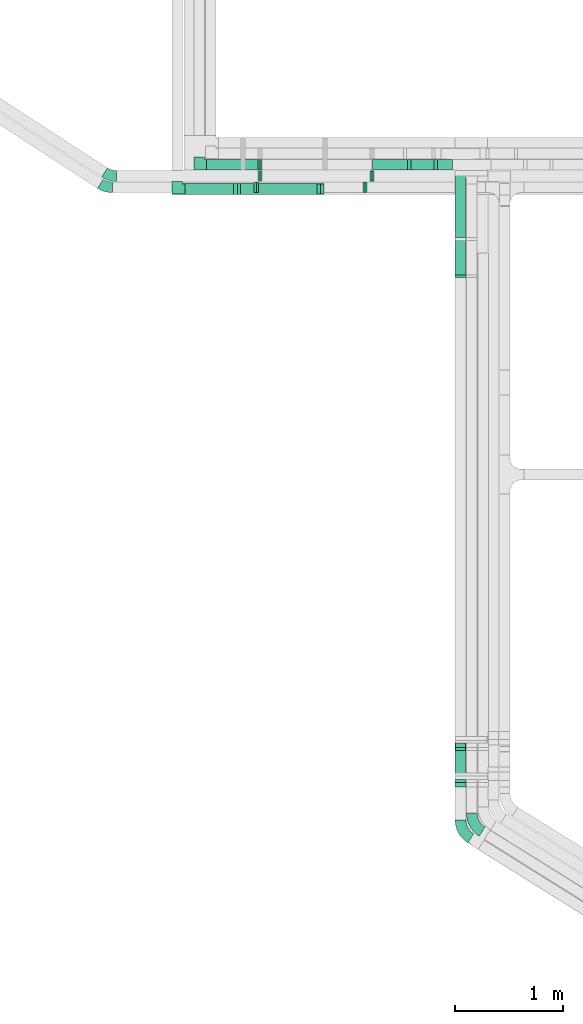
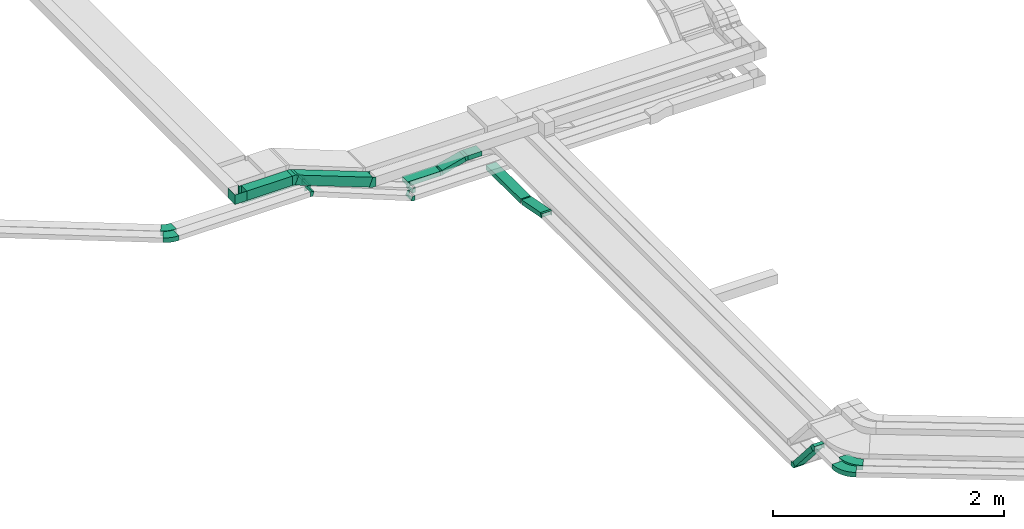
# One storey, part 3 of 18: 18 flow fittings, 9 flow segments.
"""IFC2X3 building model written with IfcOpenShell, lengths in millimetres."""

from ifc_helpers import new_model, entity, si_unit, converted_unit, derived_unit, direction, frame, frame_2d, origin, origin_2d_with_axis, place, context, subcontext, project, spatial, polyline, circle_curve, parameter, trimmed, segment, composite_curve, rectangle, outline, extrude, faceted_brep, source, transform, mapped, material, type_object, type_shapes, element, save


model = new_model("IFC2X3")

# Units and contexts
model_context = context("Model", 3, precision=0.01, world=origin(), true_north=direction((6.12303176911189e-17, 1.0)))
body_context = subcontext(model_context, "Body", "Model", "MODEL_VIEW")
ifc_project = project(units=[si_unit("LENGTHUNIT", "METRE", prefix="MILLI"), si_unit("AREAUNIT", "SQUARE_METRE"), si_unit("VOLUMEUNIT", "CUBIC_METRE"), converted_unit("PLANEANGLEUNIT", "DEGREE", entity("IfcRatioMeasure", 0.0174532925199433), si_unit("PLANEANGLEUNIT", "RADIAN"), dimensions=[0, 0, 0, 0, 0, 0, 0]), si_unit("MASSUNIT", "GRAM", prefix="KILO"), derived_unit("MASSDENSITYUNIT", [(si_unit("MASSUNIT", "GRAM", prefix="KILO"), 1), (si_unit("LENGTHUNIT", "METRE"), -3)]), derived_unit("MOMENTOFINERTIAUNIT", [(si_unit("LENGTHUNIT", "METRE"), 4)]), si_unit("TIMEUNIT", "SECOND"), si_unit("FREQUENCYUNIT", "HERTZ"), si_unit("THERMODYNAMICTEMPERATUREUNIT", "DEGREE_CELSIUS"), derived_unit("THERMALTRANSMITTANCEUNIT", [(si_unit("MASSUNIT", "GRAM", prefix="KILO"), 1), (si_unit("THERMODYNAMICTEMPERATUREUNIT", "KELVIN"), -1), (si_unit("TIMEUNIT", "SECOND"), -3)]), derived_unit("VOLUMETRICFLOWRATEUNIT", [(si_unit("LENGTHUNIT", "METRE"), 3), (si_unit("TIMEUNIT", "SECOND"), -1)]), derived_unit("MASSFLOWRATEUNIT", [(si_unit("MASSUNIT", "GRAM", prefix="KILO"), 1), (si_unit("TIMEUNIT", "SECOND"), -1)]), derived_unit("ROTATIONALFREQUENCYUNIT", [(si_unit("TIMEUNIT", "SECOND"), -1)]), si_unit("ELECTRICCURRENTUNIT", "AMPERE"), si_unit("ELECTRICVOLTAGEUNIT", "VOLT"), si_unit("POWERUNIT", "WATT"), si_unit("FORCEUNIT", "NEWTON", prefix="KILO"), si_unit("ILLUMINANCEUNIT", "LUX"), si_unit("LUMINOUSFLUXUNIT", "LUMEN"), si_unit("LUMINOUSINTENSITYUNIT", "CANDELA"), derived_unit("USERDEFINED", [(si_unit("MASSUNIT", "GRAM", prefix="KILO"), -1), (si_unit("LENGTHUNIT", "METRE"), -2), (si_unit("TIMEUNIT", "SECOND"), 3), (si_unit("LUMINOUSFLUXUNIT", "LUMEN"), 1)]), derived_unit("LINEARVELOCITYUNIT", [(si_unit("LENGTHUNIT", "METRE"), 1), (si_unit("TIMEUNIT", "SECOND"), -1)]), si_unit("PRESSUREUNIT", "PASCAL"), derived_unit("USERDEFINED", [(si_unit("LENGTHUNIT", "METRE"), -2), (si_unit("MASSUNIT", "GRAM", prefix="KILO"), 1), (si_unit("TIMEUNIT", "SECOND"), -2)]), derived_unit("LINEARFORCEUNIT", [(si_unit("MASSUNIT", "GRAM", prefix="KILO"), 1), (si_unit("LENGTHUNIT", "METRE"), 1), (si_unit("TIMEUNIT", "SECOND"), -2), (si_unit("LENGTHUNIT", "METRE"), -1)]), derived_unit("PLANARFORCEUNIT", [(si_unit("MASSUNIT", "GRAM", prefix="KILO"), 1), (si_unit("LENGTHUNIT", "METRE"), 1), (si_unit("TIMEUNIT", "SECOND"), -2), (si_unit("LENGTHUNIT", "METRE"), -2)])], contexts=[model_context])

# Site, building, storey
site_placement = place(None, frame((0.0, -0.00077364408347762, 0.0)))
site = spatial("IfcSite", under=ifc_project, at=site_placement, CompositionType="ELEMENT")
building_placement = place(site_placement, origin())
building = spatial("IfcBuilding", under=site, at=building_placement, CompositionType="ELEMENT")
storey_placement = place(building_placement, frame((0.0, 0.0, 19800.0)))
storey = spatial("IfcBuildingStorey", under=building, at=storey_placement, CompositionType="ELEMENT", Elevation=19800.0)

# Flow segments
cable_carrier_segment_type = type_object("IfcCableCarrierSegmentType", PredefinedType="CABLETRAYSEGMENT")
flow_segment_1_placement = place(storey_placement, frame((17241.4672637034, 10049.8208448265, 2600.0)))
element("IfcFlowSegment", 1, at=flow_segment_1_placement, inside=storey, type_object=cable_carrier_segment_type, context=body_context, shape_type="SweptSolid", body=[
    extrude(rectangle(XDim=324.377510430256, YDim=99.9999999999989, at=origin_2d_with_axis()), frame((162.188755215128, 50.0, 0.0), z_axis=(0.0, 0.0, 1.0), x_axis=(-1.0, 0.0, 0.0)), (0.0, 0.0, 1.0), 49.999999999993),
])
flow_segment_2_placement = place(storey_placement, frame((18007.1440474966, 4355.16048179056, 2631.28882558187)))
element("IfcFlowSegment", 2, at=flow_segment_2_placement, inside=storey, type_object=cable_carrier_segment_type, context=body_context, shape_type="SweptSolid", body=[
    extrude(rectangle(XDim=49.999999999999, YDim=99.9999999999989, at=frame_2d((-2.04281036531029e-13, 0.0), x_axis=(1.0, 0.0))), frame((50.0, 327.133678626218, 16.4014757247622), z_axis=(0.0, -0.656059028990503, 0.754709580222776), x_axis=(0.0, 0.754709580222776, 0.656059028990503)), (0.0, 0.0, 1.0), 469.87530923093),
])
flow_segment_3_placement = place(storey_placement, frame((15498.6244304067, 9824.22079653059, 3200.0)))
element("IfcFlowSegment", 3, at=flow_segment_3_placement, inside=storey, type_object=cable_carrier_segment_type, context=body_context, shape_type="SweptSolid", body=[
    extrude(rectangle(XDim=454.2591038131, YDim=99.9999999999989, at=frame_2d((-1.08002495835535e-12, 1.08357767203415e-12), x_axis=(1.0, 0.0))), frame((227.129551906549, 50.0, 0.0), z_axis=(0.0, 0.0, 1.0), x_axis=(-1.0, 0.0, 0.0)), (0.0, 0.0, 1.0), 99.9999999999989),
])
flow_segment_4_placement = place(storey_placement, frame((15982.1363342834, 9824.22079653059, 2911.93512366509)))
element("IfcFlowSegment", 4, at=flow_segment_4_placement, inside=storey, type_object=cable_carrier_segment_type, context=body_context, shape_type="SweptSolid", body=[
    extrude(rectangle(XDim=99.9999999999955, YDim=99.9999999999989, at=origin_2d_with_axis()), frame((17.800348702831, 50.0, 329.405587764782), z_axis=(0.934483298097407, 0.0, -0.356006974056679), x_axis=(0.356006974056679, 0.0, 0.934483298097407)), (0.0, 0.0, 1.0), 794.033385466518),
])
flow_segment_5_placement = place(storey_placement, frame((15701.7727830703, 10049.8208448265, 3000.0)))
element("IfcFlowSegment", 5, at=flow_segment_5_placement, inside=storey, type_object=cable_carrier_segment_type, context=body_context, shape_type="SweptSolid", body=[
    extrude(rectangle(XDim=474.612051507651, YDim=99.9999999999989, at=frame_2d((1.09423581307055e-12, 1.08357767203415e-12), x_axis=(1.0, 0.0))), frame((237.306025753825, 50.0, 0.0), z_axis=(0.0, 0.0, 1.0), x_axis=(-1.0, 0.0, 0.0)), (0.0, 0.0, 1.0), 49.9999999999973),
])
flow_segment_6_placement = place(storey_placement, frame((17841.4672637035, 10049.8208448265, 2667.29295172665)))
element("IfcFlowSegment", 6, at=flow_segment_6_placement, inside=storey, type_object=cable_carrier_segment_type, context=body_context, shape_type="SweptSolid", body=[
    extrude(rectangle(XDim=140.676783793121, YDim=99.9999999999989, at=frame_2d((1.08002495835535e-12, 1.08357767203415e-12), x_axis=(1.0, 0.0))), frame((70.3383918965658, 50.0, 0.0), z_axis=(0.0, 0.0, 1.0), x_axis=(-1.0, 0.0, 0.0)), (0.0, 0.0, 1.0), 49.9999999999973),
])
flow_segment_7_placement = place(storey_placement, frame((17583.4389746183, 10049.8208448265, 2604.02002912242)))
element("IfcFlowSegment", 7, at=flow_segment_7_placement, inside=storey, type_object=cable_carrier_segment_type, context=body_context, shape_type="SweptSolid", body=[
    extrude(rectangle(XDim=49.9999999999963, YDim=99.9999999999989, at=frame_2d((0.0, 2.8066438062524e-13), x_axis=(0.0, 1.0))), frame((6.47047612756317, 50.0, 24.1481456572253), z_axis=(0.965925826289074, 0.0, 0.2588190451025), x_axis=(0.0, 1.0, 0.0)), (0.0, 0.0, 1.0), 235.518225265272),
])
flow_segment_8_placement = place(storey_placement, frame((18007.1440474966, 9421.82302171589, 2527.53156505895)))
element("IfcFlowSegment", 8, at=flow_segment_8_placement, inside=storey, type_object=cable_carrier_segment_type, context=body_context, shape_type="SweptSolid", body=[
    extrude(rectangle(XDim=49.9999999999995, YDim=600.828950899031, at=frame_2d((-1.10844666778576e-12, 2.1547208461925e-12), x_axis=(0.0, 1.0))), frame((0.0, 300.615545758793, 27.5449040265772), z_axis=(1.0, 0.0, 0.0), x_axis=(0.0, -0.999964092494124, 0.00847429775285375)), (0.0, 0.0, 1.0), 99.9999999999989),
])
flow_segment_9_placement = place(storey_placement, frame((18007.1440474966, 9067.35350571272, 2535.04544174174)))
element("IfcFlowSegment", 9, at=flow_segment_9_placement, inside=storey, type_object=cable_carrier_segment_type, context=body_context, shape_type="SweptSolid", body=[
    extrude(rectangle(XDim=50.0, YDim=336.179548958073, at=frame_2d((5.25801624462474e-13, 1.04805053524615e-13), x_axis=(0.0, 1.0))), frame((0.0, 169.78676712889, 56.2858919461021), z_axis=(1.0, 0.0, 0.0), x_axis=(0.0, 0.982015379189401, -0.188800940239973)), (0.0, 0.0, 1.0), 99.9999999999968),
])

# Flow fittings
ifc_material = material()
cable_carrier_fitting_type_1 = type_object("IfcCableCarrierFittingType", PredefinedType="NOTDEFINED", material=ifc_material)
shared_shape_1 = source(origin(), body_context, "Body", "Brep", [
    faceted_brep([(-70.0, 50.0, -25.0), (-70.0, -50.0, -25.0), (-70.0, -50.0, 25.0), (-70.0, -47.4600000101598, 25.0), (-70.0, -47.4600000101598, -22.4600000101565), (-70.0, 47.4600000101602, -22.4600000101565), (-70.0, 47.4600000101602, 25.0), (-70.0, 50.0, 25.0), (-50.0, 50.0, -25.0), (-50.0, 70.0, -25.0), (50.0, 70.0, -25.0), (50.0, -50.0, -25.0), (50.0, -50.0, 25.0), (50.0, 70.0, 25.0), (47.4600000101603, 70.0, 25.0), (47.4600000101596, -47.4600000101602, 25.0), (47.4600000101596, -47.4600000101602, -22.4600000101565), (47.4600000101603, 70.0, -22.4600000101565), (-47.4600000101597, 70.0, -22.4600000101565), (-47.4600000101602, 47.4600000101602, -22.4600000101565), (-47.4600000101602, 47.4600000101602, 25.0), (-47.4600000101597, 70.0, 25.0), (-50.0, 70.0, 25.0), (-50.0, 50.0, 25.0)], [[[0, 1, 2, 3, 4, 5, 6, 7]], [[1, 0, 8, 9, 10, 11]], [[2, 1, 11, 12]], [[3, 2, 12, 13, 14, 15]], [[4, 3, 15, 16]], [[5, 4, 16, 17, 18, 19]], [[6, 5, 19, 20]], [[7, 6, 20, 21, 22, 23]], [[0, 7, 23, 8]], [[9, 22, 21, 18, 17, 14, 13, 10]], [[12, 11, 10, 13]], [[16, 15, 14, 17]], [[20, 19, 18, 21]], [[8, 23, 22, 9]]]),
])
type_shapes(cable_carrier_fitting_type_1, [shared_shape_1])
flow_fitting_1_placement = place(storey_placement, frame((15631.7727830703, 10099.8208448265, 3025.0), z_axis=(0.0, 0.0, 1.0), x_axis=(0.0, -1.0, 0.0)))
element("IfcFlowFitting", 10, at=flow_fitting_1_placement, inside=storey, type_object=cable_carrier_fitting_type_1, material=ifc_material, context=body_context, shape_type="MappedRepresentation", body=[
    mapped(shared_shape_1, transform((0.0, 0.0, 0.0), scale=1.0)),
])
cable_carrier_fitting_type_2 = type_object("IfcCableCarrierFittingType", PredefinedType="NOTDEFINED", material=ifc_material)
shared_shape_2 = source(origin(), body_context, "Body", "Brep", [
    faceted_brep([(-70.0, 50.0, -50.0), (-70.0, -50.0, -50.0), (-70.0, -50.0, 50.0), (-70.0, -47.4600000101598, 50.0), (-70.0, -47.4600000101598, -47.4600000101565), (-70.0, 47.4600000101602, -47.4600000101565), (-70.0, 47.4600000101602, 50.0), (-70.0, 50.0, 50.0), (-50.0, 50.0, -50.0), (-50.0, 70.0, -50.0), (50.0, 70.0, -50.0), (50.0, -50.0, -50.0), (50.0, -50.0, 50.0), (50.0, 70.0, 50.0), (47.4600000101603, 70.0, 50.0), (47.4600000101596, -47.4600000101602, 50.0), (47.4600000101596, -47.4600000101602, -47.4600000101565), (47.4600000101603, 70.0, -47.4600000101565), (-47.4600000101597, 70.0, -47.4600000101565), (-47.4600000101602, 47.4600000101602, -47.4600000101565), (-47.4600000101602, 47.4600000101602, 50.0), (-47.4600000101597, 70.0, 50.0), (-50.0, 70.0, 50.0), (-50.0, 50.0, 50.0)], [[[0, 1, 2, 3, 4, 5, 6, 7]], [[1, 0, 8, 9, 10, 11]], [[2, 1, 11, 12]], [[3, 2, 12, 13, 14, 15]], [[4, 3, 15, 16]], [[5, 4, 16, 17, 18, 19]], [[6, 5, 19, 20]], [[7, 6, 20, 21, 22, 23]], [[0, 7, 23, 8]], [[9, 22, 21, 18, 17, 14, 13, 10]], [[12, 11, 10, 13]], [[16, 15, 14, 17]], [[20, 19, 18, 21]], [[8, 23, 22, 9]]]),
])
type_shapes(cable_carrier_fitting_type_2, [shared_shape_2])
flow_fitting_2_placement = place(storey_placement, frame((15428.6244304067, 9874.2207965306, 3250.0), z_axis=(0.0, 0.0, 1.0), x_axis=(0.0, -1.0, 0.0)))
element("IfcFlowFitting", 11, at=flow_fitting_2_placement, inside=storey, type_object=cable_carrier_fitting_type_2, material=ifc_material, context=body_context, shape_type="MappedRepresentation", body=[
    mapped(shared_shape_2, transform((0.0, 0.0, 0.0), scale=1.0)),
])
cable_carrier_fitting_type_3 = type_object("IfcCableCarrierFittingType", Name="470_DKC_S5_Variable Angle Elbow 0-45:-", PredefinedType="NOTDEFINED", material=ifc_material)
shared_shape_3 = source(origin(), body_context, "Body", "SweptSolid", [
    extrude(outline(composite_curve([segment(polyline([(-85.6872894317013, -97.2200856007182), (-84.6872894317002, -97.2200856007182)]), True, "CONTINUOUS"), segment(trimmed(circle_curve(frame_2d((-84.6872894317005, 152.779914399281), x_axis=(0.0, -1.0)), 250.0), [parameter(0.0)], [parameter(57.9999999999997)], True, "PARAMETER"), True, "CONTINUOUS"), segment(polyline([(127.324734607405, 20.3000983409794), (127.854653871638, 21.1481464371359)]), True, "CONTINUOUS"), segment(polyline([(127.854653871638, 21.1481464371359), (43.049844255996, 74.1400728604566)]), True, "CONTINUOUS"), segment(polyline([(43.049844255996, 74.1400728604566), (42.5199249917629, 73.2920247643002)]), True, "CONTINUOUS"), segment(trimmed(circle_curve(frame_2d((-84.6872894317005, 152.779914399281), x_axis=(0.0, -1.0)), 150.0), [parameter(0.0)], [parameter(57.9999999999997)], True, "PARAMETER"), False, "CONTINUOUS"), segment(polyline([(-84.6872894317002, 2.77991439928172), (-85.6872894317013, 2.77991439928172)]), True, "CONTINUOUS"), segment(polyline([(-85.6872894317013, 2.77991439928172), (-85.6872894317013, -97.2200856007182)]), True, "CONTINUOUS")], self_intersect=False)), frame((-26.1745208588429, 47.2200856007101, -25.0)), (0.0, 0.0, 1.0), 49.9999999999998),
])
type_shapes(cable_carrier_fitting_type_3, [shared_shape_3])
for number, where, z_axis, x_axis, name in (
    (12, (18057.1440474967, 3908.48686108932, 3025.0), (0.0, 0.0, 1.0), (0.0, -1.0, 0.0), "470_DKC_S5_Variable Angle Elbow 0-45:-"),
    (13, (18162.1440474966, 3970.75637448707, 3025.0), (0.0, 0.0, 1.0), (0.0, -1.0, 0.0), "470_DKC_S5_Variable Angle Elbow 0-45:-"),
):
    element("IfcFlowFitting", number, at=place(storey_placement, frame(where, z_axis=z_axis, x_axis=x_axis)), inside=storey, type_object=cable_carrier_fitting_type_3, material=ifc_material, Name=name, ObjectType="470_DKC_S5_Variable Angle Elbow 0-45:-", context=body_context, shape_type="MappedRepresentation", body=[
        mapped(shared_shape_3, transform((0.0, 0.0, 0.0), scale=1.0)),
    ])
cable_carrier_fitting_type_4 = type_object("IfcCableCarrierFittingType", PredefinedType="NOTDEFINED", material=ifc_material)
shared_shape_4 = source(origin(), body_context, "Body", "Brep", [
    faceted_brep([(-30.0649440542927, -25.0, 50.0), (-30.0649440542926, 25.0, 50.0), (-30.0649440542926, 25.0, 47.4600000101635), (-30.0649440542927, -22.4600000101599, 47.4600000101635), (-30.0649440542927, -22.4600000101599, -47.4600000101565), (-30.0649440542926, 25.0, -47.4600000101565), (-30.0649440542926, 25.0, -50.0), (-30.0649440542927, -25.0, -50.0), (38.5921175084832, 6.28882558187459, 50.0), (38.5921175084832, 6.28882558187459, -50.0), (0.856638497343776, 39.091777031399, -50.0), (0.856638497343783, 39.091777031399, -47.4600000101565), (36.6751551823852, 7.95521550884487, -47.4600000101565), (36.6751551823852, 7.95521550884487, 47.4600000101635), (0.856638497343774, 39.091777031399, 47.4600000101635), (0.85663849734377, 39.091777031399, 50.0), (11.3931563883155, -25.0, 50.0), (-11.3931563883146, 25.0, 50.0), (-11.3931563883146, 25.0, 47.4600000101635), (10.2356117038927, -22.46000001016, 47.4600000101635), (10.2356117038927, -22.46000001016, -47.4600000101565), (-11.3931563883146, 25.0, -47.4600000101565), (-11.3931563883146, 25.0, -50.0), (11.3931563883153, -25.0, -50.0)], [[[0, 1, 2, 3, 4, 5, 6, 7]], [[8, 9, 10, 11, 12, 13, 14, 15]], [[1, 0, 16, 8, 15, 17]], [[2, 1, 17, 18]], [[3, 2, 18, 14, 13, 19]], [[4, 3, 19, 20]], [[5, 4, 20, 12, 11, 21]], [[6, 5, 21, 22]], [[7, 6, 22, 10, 9, 23]], [[0, 7, 23, 16]], [[18, 17, 15, 14]], [[20, 19, 13, 12]], [[22, 21, 11, 10]], [[16, 23, 9, 8]]]),
])
type_shapes(cable_carrier_fitting_type_4, [shared_shape_4])
for number, where, z_axis, x_axis in (
    (14, (18057.1440474966, 4354.30384329321, 3025.0), (-1.0, 0.0, 0.0), (0.0, 1.0, 0.0)),
    (15, (18057.1440474966, 4702.01853841968, 2625.0), (1.0, 0.0, 0.0), (0.0, 0.656059028990493, -0.754709580222785)),
):
    element("IfcFlowFitting", number, at=place(storey_placement, frame(where, z_axis=z_axis, x_axis=x_axis)), inside=storey, type_object=cable_carrier_fitting_type_4, material=ifc_material, context=body_context, shape_type="MappedRepresentation", body=[
        mapped(shared_shape_4, transform((0.0, 0.0, 0.0), scale=1.0)),
    ])
cable_carrier_fitting_type_5 = type_object("IfcCableCarrierFittingType", PredefinedType="NOTDEFINED", material=ifc_material)
shared_shape_5 = source(origin(), body_context, "Body", "Brep", [
    faceted_brep([(-15.1217640867585, -25.0, 50.0), (-15.1217640867583, 25.0, 50.0), (-15.1217640867583, 25.0, 47.4600000101635), (-15.1217640867585, -22.4600000101599, 47.4600000101635), (-15.1217640867585, -22.4600000101599, -47.4600000101565), (-15.1217640867583, 25.0, -47.4600000101565), (-15.1217640867583, 25.0, -50.0), (-15.1217640867585, -25.0, -50.0), (23.0312103282627, -17.9786289775097, 50.0), (23.0312103282627, -17.9786289775097, -50.0), (5.23086162542895, 28.7455359273607, -50.0), (5.23086162542895, 28.7455359273607, -47.4600000101565), (22.1269526177758, -15.6050414098367, -47.4600000101565), (22.1269526177758, -15.6050414098367, 47.4600000101635), (5.23086162542895, 28.7455359273607, 47.4600000101635), (5.23086162542895, 28.7455359273607, 50.0), (4.60080185761804, -25.0, 50.0), (-4.60080185761728, 25.0, 50.0), (-4.60080185761728, 25.0, 47.4600000101635), (4.13336039075377, -22.46000001016, 47.4600000101635), (4.13336039075377, -22.46000001016, -47.4600000101565), (-4.60080185761728, 25.0, -47.4600000101565), (-4.60080185761728, 25.0, -50.0), (4.60080185761796, -25.0, -50.0)], [[[0, 1, 2, 3, 4, 5, 6, 7]], [[8, 9, 10, 11, 12, 13, 14, 15]], [[1, 0, 16, 8, 15, 17]], [[2, 1, 17, 18]], [[3, 2, 18, 14, 13, 19]], [[4, 3, 19, 20]], [[5, 4, 20, 12, 11, 21]], [[6, 5, 21, 22]], [[7, 6, 22, 10, 9, 23]], [[0, 7, 23, 16]], [[18, 17, 15, 14]], [[20, 19, 13, 12]], [[22, 21, 11, 10]], [[16, 23, 9, 8]]]),
])
type_shapes(cable_carrier_fitting_type_5, [shared_shape_5])
for number, where, z_axis, x_axis in (
    (16, (16191.5065986647, 9994.23549574398, 3025.0), (0.0, 1.0, 0.0), (1.0, 0.0, 0.0)),
    (17, (17241.4672637034, 9994.235495744, 2625.0), (0.0, -1.0, 0.0), (0.934483298097409, 0.0, -0.356006974056673)),
    (18, (16191.5065986647, 10099.8208448265, 3025.0), (0.0, -1.0, 0.0), (-0.93448329809741, 0.0, 0.356006974056672)),
):
    element("IfcFlowFitting", number, at=place(storey_placement, frame(where, z_axis=z_axis, x_axis=x_axis)), inside=storey, type_object=cable_carrier_fitting_type_5, material=ifc_material, context=body_context, shape_type="MappedRepresentation", body=[
        mapped(shared_shape_5, transform((0.0, 0.0, 0.0), scale=1.0)),
    ])
cable_carrier_fitting_type_6 = type_object("IfcCableCarrierFittingType", PredefinedType="NOTDEFINED", material=ifc_material)
shared_shape_6 = source(origin(), body_context, "Body", "Brep", [
    faceted_brep([(-24.3233678019943, -50.0, 50.0), (-24.323367801994, 50.0, 50.0), (-24.323367801994, 50.0, 47.4600000101635), (-24.3233678019943, -47.4600000101599, 47.4600000101635), (-24.3233678019943, -47.4600000101599, -47.4600000101565), (-24.323367801994, 50.0, -47.4600000101565), (-24.323367801994, 50.0, -50.0), (-24.3233678019943, -50.0, -50.0), (40.5301296672784, -38.0648763348152, 50.0), (40.5301296672784, -38.0648763348153, -50.0), (4.9294322616109, 55.3834534749256, -50.0), (4.92943226161089, 55.3834534749256, -47.4600000101565), (39.6258719567915, -35.6912887671422, -47.4600000101565), (39.6258719567915, -35.6912887671421, 47.4600000101635), (4.9294322616109, 55.3834534749256, 47.4600000101635), (4.92943226161089, 55.3834534749256, 50.0), (9.20160371523567, -50.0, 50.0), (-9.20160371523487, 50.0, 50.0), (-9.20160371523487, 50.0, 47.4600000101635), (8.7341622483714, -47.46000001016, 47.4600000101635), (8.7341622483714, -47.46000001016, -47.4600000101565), (-9.20160371523487, 50.0, -47.4600000101565), (-9.20160371523487, 50.0, -50.0), (9.20160371523559, -50.0, -50.0)], [[[0, 1, 2, 3, 4, 5, 6, 7]], [[8, 9, 10, 11, 12, 13, 14, 15]], [[1, 0, 16, 8, 15, 17]], [[2, 1, 17, 18]], [[3, 2, 18, 14, 13, 19]], [[4, 3, 19, 20]], [[5, 4, 20, 12, 11, 21]], [[6, 5, 21, 22]], [[7, 6, 22, 10, 9, 23]], [[0, 7, 23, 16]], [[18, 17, 15, 14]], [[20, 19, 13, 12]], [[22, 21, 11, 10]], [[16, 23, 9, 8]]]),
])
type_shapes(cable_carrier_fitting_type_6, [shared_shape_6])
for number, where, z_axis, x_axis in (
    (19, (15977.2069020218, 9874.22079653059, 3250.0), (0.0, -1.0, 0.0), (-0.934483298097408, 0.0, 0.356006974056677)),
    (20, (16764.6774008009, 9874.22079653059, 2950.0), (0.0, -1.0, 0.0), (0.934483298097408, 0.0, -0.356006974056676)),
):
    element("IfcFlowFitting", number, at=place(storey_placement, frame(where, z_axis=z_axis, x_axis=x_axis)), inside=storey, type_object=cable_carrier_fitting_type_6, material=ifc_material, context=body_context, shape_type="MappedRepresentation", body=[
        mapped(shared_shape_6, transform((0.0, 0.0, 0.0), scale=1.0)),
    ])
cable_carrier_fitting_type_7 = type_object("IfcCableCarrierFittingType", PredefinedType="NOTDEFINED", material=ifc_material)
shared_shape_7 = source(origin(), body_context, "Body", "Brep", [
    faceted_brep([(-15.5075067807849, -25.0, 50.0), (-15.5075067807848, 25.0, 50.0), (-15.5075067807848, 25.0, 47.4600000101635), (-15.5075067807849, -22.4600000101599, 47.4600000101635), (-15.5075067807849, -22.4600000101599, -47.4600000101565), (-15.5075067807848, 25.0, -47.4600000101565), (-15.5075067807848, 25.0, -50.0), (-15.5075067807849, -25.0, -50.0), (23.6312820025375, -17.5227074812281, 50.0), (23.6312820025375, -17.5227074812281, -50.0), (5.19945659195664, 28.9559737827005, -50.0), (5.19945659195664, 28.9559737827005, -47.4600000101565), (22.6949452754254, -15.161590482465, -47.4600000101565), (22.6949452754254, -15.161590482465, 47.4600000101635), (5.19945659195664, 28.9559737827005, 47.4600000101635), (5.19945659195664, 28.9559737827005, 50.0), (4.77613944581188, -25.0, 50.0), (-4.77613944581108, 25.0, 50.0), (-4.77613944581108, 25.0, 47.4600000101635), (4.29088368005838, -22.46000001016, 47.4600000101635), (4.29088368005838, -22.46000001016, -47.4600000101565), (-4.77613944581108, 25.0, -47.4600000101565), (-4.77613944581108, 25.0, -50.0), (4.7761394458118, -25.0, -50.0)], [[[0, 1, 2, 3, 4, 5, 6, 7]], [[8, 9, 10, 11, 12, 13, 14, 15]], [[1, 0, 16, 8, 15, 17]], [[2, 1, 17, 18]], [[3, 2, 18, 14, 13, 19]], [[4, 3, 19, 20]], [[5, 4, 20, 12, 11, 21]], [[6, 5, 21, 22]], [[7, 6, 22, 10, 9, 23]], [[0, 7, 23, 16]], [[18, 17, 15, 14]], [[20, 19, 13, 12]], [[22, 21, 11, 10]], [[16, 23, 9, 8]]]),
])
type_shapes(cable_carrier_fitting_type_7, [shared_shape_7])
for number, where, z_axis, x_axis in (
    (21, (16158.616361479, 9890.22583236336, 3028.39732187967), (0.0, 1.0, 0.0), (1.0, 0.0, 0.0)),
    (22, (17175.8447221385, 9890.22583236337, 2625.0), (0.0, -1.0, 0.0), (0.929573625278572, 0.0, -0.368636508211617)),
):
    element("IfcFlowFitting", number, at=place(storey_placement, frame(where, z_axis=z_axis, x_axis=x_axis)), inside=storey, type_object=cable_carrier_fitting_type_7, material=ifc_material, context=body_context, shape_type="MappedRepresentation", body=[
        mapped(shared_shape_7, transform((0.0, 0.0, 0.0), scale=1.0)),
    ])
cable_carrier_fitting_type_8 = type_object("IfcCableCarrierFittingType", PredefinedType="NOTDEFINED", material=ifc_material)
shared_shape_8 = source(origin(), body_context, "Body", "Brep", [
    faceted_brep([(-12.2408873673373, -25.0, 50.0), (-12.2408873673371, 25.0, 50.0), (-12.2408873673371, 25.0, 47.4600000101635), (-12.2408873673373, -22.46000001016, 47.4600000101635), (-12.2408873673373, -22.46000001016, -47.4600000101565), (-12.2408873673371, 25.0, -47.4600000101565), (-12.2408873673371, 25.0, -50.0), (-12.2408873673373, -25.0, -50.0), (18.2942653723936, -20.9799708775852, 50.0), (18.2942653723936, -20.9799708775852, -50.0), (5.35331311721434, 27.316320436854, -50.0), (5.35331311721434, 27.316320436854, -47.4600000101565), (17.6368650004601, -18.5265192886255, -47.4600000101565), (17.6368650004601, -18.5265192886255, 47.4600000101635), (5.35331311721434, 27.316320436854, 47.4600000101635), (5.35331311721434, 27.316320436854, 50.0), (3.29131243969929, -25.0, 50.0), (-3.29131243969851, 25.0, 50.0), (-3.29131243969851, 25.0, 47.4600000101635), (2.95691509716341, -22.46000001016, 47.4600000101635), (2.95691509716341, -22.46000001016, -47.4600000101565), (-3.29131243969851, 25.0, -47.4600000101565), (-3.29131243969851, 25.0, -50.0), (3.29131243969922, -25.0, -50.0)], [[[0, 1, 2, 3, 4, 5, 6, 7]], [[8, 9, 10, 11, 12, 13, 14, 15]], [[1, 0, 16, 8, 15, 17]], [[2, 1, 17, 18]], [[3, 2, 18, 14, 13, 19]], [[4, 3, 19, 20]], [[5, 4, 20, 12, 11, 21]], [[6, 5, 21, 22]], [[7, 6, 22, 10, 9, 23]], [[0, 7, 23, 16]], [[18, 17, 15, 14]], [[20, 19, 13, 12]], [[22, 21, 11, 10]], [[16, 23, 9, 8]]]),
])
type_shapes(cable_carrier_fitting_type_8, [shared_shape_8])
for number, where, z_axis, x_axis in (
    (23, (17829.2263763361, 10099.8208448265, 2692.29295172665), (0.0, 1.0, 0.0), (0.965925826289088, 0.0, 0.258819045102448)),
    (24, (17578.0856615011, 10099.8208448266, 2625.0), (0.0, 1.0, 0.0), (-0.965925826289075, 0.0, -0.258819045102496)),
):
    element("IfcFlowFitting", number, at=place(storey_placement, frame(where, z_axis=z_axis, x_axis=x_axis)), inside=storey, type_object=cable_carrier_fitting_type_8, material=ifc_material, context=body_context, shape_type="MappedRepresentation", body=[
        mapped(shared_shape_8, transform((0.0, 0.0, 0.0), scale=1.0)),
    ])
cable_carrier_fitting_type_9 = type_object("IfcCableCarrierFittingType", PredefinedType="NOTDEFINED", material=ifc_material)
shared_shape_9 = source(origin(), body_context, "Body", "Brep", [
    faceted_brep([(-10.2391378100429, -25.0, 50.0), (-10.2391378100427, 25.0, 50.0), (-10.2391378100427, 25.0, 47.4600000101635), (-10.2391378100429, -22.46000001016, 47.4600000101635), (-10.2391378100429, -22.46000001016, -47.4600000101565), (-10.2391378100427, 25.0, -47.4600000101565), (-10.2391378100427, 25.0, -50.0), (-10.2391378100429, -25.0, -50.0), (14.7750143051017, -22.6172256339527, 50.0), (14.7750143051017, -22.6172256339528, -50.0), (5.33496729310332, 26.4835433255173, -50.0), (5.33496729310332, 26.4835433255173, -47.4600000101565), (14.2954599188104, -20.122906580789, -47.4600000101565), (14.2954599188104, -20.122906580789, 47.4600000101635), (5.33496729310332, 26.4835433255173, 47.4600000101635), (5.33496729310332, 26.4835433255173, 50.0), (2.3814262772927, -25.0, 50.0), (-2.38142627729195, 25.0, 50.0), (-2.38142627729195, 25.0, 47.4600000101635), (2.13947336848757, -22.46000001016, 47.4600000101635), (2.13947336848757, -22.46000001016, -47.4600000101565), (-2.38142627729195, 25.0, -47.4600000101565), (-2.38142627729195, 25.0, -50.0), (2.38142627729265, -25.0, -50.0)], [[[0, 1, 2, 3, 4, 5, 6, 7]], [[8, 9, 10, 11, 12, 13, 14, 15]], [[1, 0, 16, 8, 15, 17]], [[2, 1, 17, 18]], [[3, 2, 18, 14, 13, 19]], [[4, 3, 19, 20]], [[5, 4, 20, 12, 11, 21]], [[6, 5, 21, 22]], [[7, 6, 22, 10, 9, 23]], [[0, 7, 23, 16]], [[18, 17, 15, 14]], [[20, 19, 13, 12]], [[22, 21, 11, 10]], [[16, 23, 9, 8]]]),
])
type_shapes(cable_carrier_fitting_type_9, [shared_shape_9])
flow_fitting_3_placement = place(storey_placement, frame((18057.1440474966, 9062.01853841963, 2625.0), z_axis=(1.0, 0.0, 0.0), x_axis=(0.0, -0.9820153791894, 0.188800940239978)))
element("IfcFlowFitting", 25, at=flow_fitting_3_placement, inside=storey, type_object=cable_carrier_fitting_type_9, material=ifc_material, context=body_context, shape_type="MappedRepresentation", body=[
    mapped(shared_shape_9, transform((0.0, 0.0, 0.0), scale=1.0)),
])
cable_carrier_fitting_type_10 = type_object("IfcCableCarrierFittingType", Name="470_DKC_S5_Variable Angle Elbow 0-45:-", PredefinedType="NOTDEFINED", material=ifc_material)
shared_shape_10 = source(origin(), body_context, "Body", "SweptSolid", [
    extrude(outline(composite_curve([segment(polyline([(-55.4235711434903, -66.2691029642116), (-54.4235711434889, -66.2691029642116)]), True, "CONTINUOUS"), segment(trimmed(circle_curve(frame_2d((-54.4235711434894, 183.730897035788), x_axis=(0.0, -1.0)), 250.0), [parameter(0.0)], [parameter(33.0000000000002)], True, "PARAMETER"), True, "CONTINUOUS"), segment(polyline([(81.7361876102682, -25.936744950567), (82.5748581782136, -25.392105915552)]), True, "CONTINUOUS"), segment(polyline([(82.5748581782136, -25.392105915552), (28.1109546767106, 58.4749508789901)]), True, "CONTINUOUS"), segment(polyline([(28.1109546767106, 58.4749508789901), (27.2722841087651, 57.930311843975)]), True, "CONTINUOUS"), segment(trimmed(circle_curve(frame_2d((-54.4235711434894, 183.730897035788), x_axis=(0.0, -1.0)), 150.0), [parameter(0.0)], [parameter(33.0000000000002)], True, "PARAMETER"), False, "CONTINUOUS"), segment(polyline([(-54.4235711434889, 33.7308970357883), (-55.4235711434903, 33.7308970357883)]), True, "CONTINUOUS"), segment(polyline([(-55.4235711434903, 33.7308970357883), (-55.4235711434903, -66.2691029642116)]), True, "CONTINUOUS")], self_intersect=False)), frame((-4.81912784891737, 16.2691029642035, -25.0)), (0.0, 0.0, 1.0), 50.0),
])
type_shapes(cable_carrier_fitting_type_10, [shared_shape_10])
for number, where, z_axis, x_axis, name in (
    (26, (14804.3583070095, 9994.23549574401, 3025.0), (0.0, 0.0, 1.0), (0.838670567945423, -0.544639035015029, 0.0), "470_DKC_S5_Variable Angle Elbow 0-45:-"),
    (27, (14766.2030436471, 9890.22583236338, 3028.39732187966), (0.0, 0.0, 1.0), (0.838670567945421, -0.544639035015031, 0.0), "470_DKC_S5_Variable Angle Elbow 0-45:-"),
):
    element("IfcFlowFitting", number, at=place(storey_placement, frame(where, z_axis=z_axis, x_axis=x_axis)), inside=storey, type_object=cable_carrier_fitting_type_10, material=ifc_material, Name=name, ObjectType="470_DKC_S5_Variable Angle Elbow 0-45:-", context=body_context, shape_type="MappedRepresentation", body=[
        mapped(shared_shape_10, transform((0.0, 0.0, 0.0), scale=1.0)),
    ])

save(model, "model.ifc")
